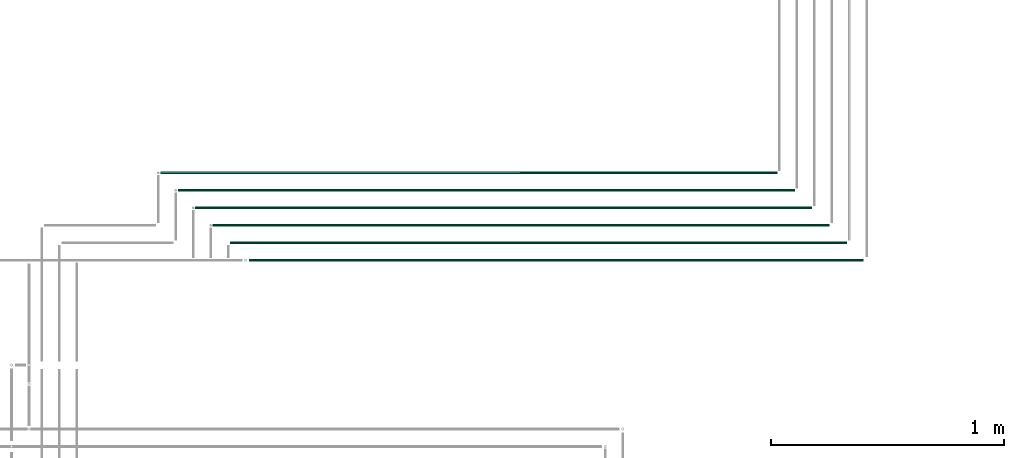
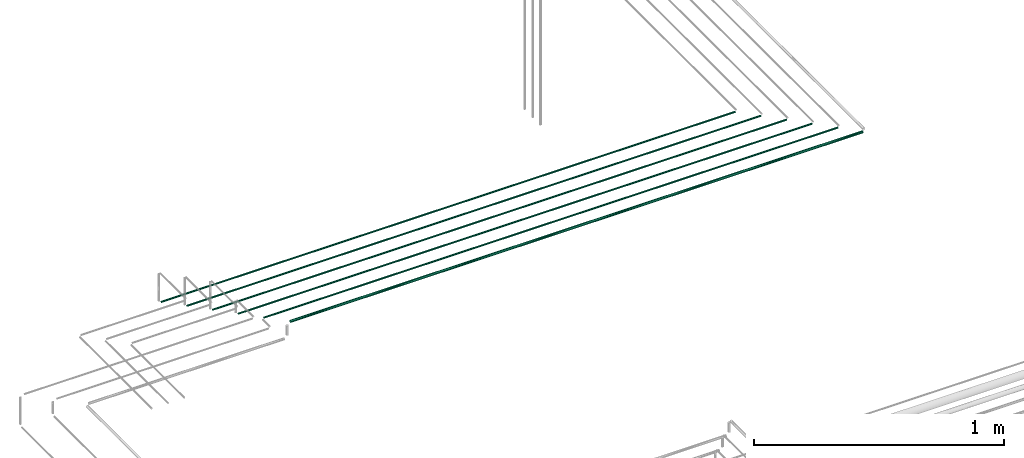
# One storey, part 30 of 331: 6 flow segments.
"""IFC2X3 building model written with IfcOpenShell, lengths in millimetres."""

from ifc_helpers import new_model, entity, si_unit, converted_unit, derived_unit, direction, frame, frame_2d, origin, place, context, subcontext, project, spatial, circle, extrude, type_object, element, save


model = new_model("IFC2X3")

# Units and contexts
model_context = context("Model", 3, precision=0.01, world=origin(), true_north=direction((6.12303176911189e-17, 1.0)))
body_context = subcontext(model_context, "Body", "Model", "MODEL_VIEW")
ifc_project = project(units=[si_unit("LENGTHUNIT", "METRE", prefix="MILLI"), si_unit("AREAUNIT", "SQUARE_METRE"), si_unit("VOLUMEUNIT", "CUBIC_METRE"), converted_unit("PLANEANGLEUNIT", "DEGREE", entity("IfcRatioMeasure", 0.0174532925199433), si_unit("PLANEANGLEUNIT", "RADIAN"), dimensions=[0, 0, 0, 0, 0, 0, 0]), si_unit("MASSUNIT", "GRAM", prefix="KILO"), derived_unit("MASSDENSITYUNIT", [(si_unit("MASSUNIT", "GRAM", prefix="KILO"), 1), (si_unit("LENGTHUNIT", "METRE"), -3)]), derived_unit("MOMENTOFINERTIAUNIT", [(si_unit("LENGTHUNIT", "METRE"), 4)]), si_unit("TIMEUNIT", "SECOND"), si_unit("FREQUENCYUNIT", "HERTZ"), si_unit("THERMODYNAMICTEMPERATUREUNIT", "DEGREE_CELSIUS"), derived_unit("THERMALTRANSMITTANCEUNIT", [(si_unit("MASSUNIT", "GRAM", prefix="KILO"), 1), (si_unit("THERMODYNAMICTEMPERATUREUNIT", "KELVIN"), -1), (si_unit("TIMEUNIT", "SECOND"), -3)]), derived_unit("VOLUMETRICFLOWRATEUNIT", [(si_unit("LENGTHUNIT", "METRE"), 3), (si_unit("TIMEUNIT", "SECOND"), -1)]), derived_unit("MASSFLOWRATEUNIT", [(si_unit("MASSUNIT", "GRAM", prefix="KILO"), 1), (si_unit("TIMEUNIT", "SECOND"), -1)]), derived_unit("ROTATIONALFREQUENCYUNIT", [(si_unit("TIMEUNIT", "SECOND"), -1)]), si_unit("ELECTRICCURRENTUNIT", "AMPERE"), si_unit("ELECTRICVOLTAGEUNIT", "VOLT"), si_unit("POWERUNIT", "WATT"), si_unit("FORCEUNIT", "NEWTON", prefix="KILO"), si_unit("ILLUMINANCEUNIT", "LUX"), si_unit("LUMINOUSFLUXUNIT", "LUMEN"), si_unit("LUMINOUSINTENSITYUNIT", "CANDELA"), derived_unit("USERDEFINED", [(si_unit("MASSUNIT", "GRAM", prefix="KILO"), -1), (si_unit("LENGTHUNIT", "METRE"), -2), (si_unit("TIMEUNIT", "SECOND"), 3), (si_unit("LUMINOUSFLUXUNIT", "LUMEN"), 1)]), derived_unit("LINEARVELOCITYUNIT", [(si_unit("LENGTHUNIT", "METRE"), 1), (si_unit("TIMEUNIT", "SECOND"), -1)]), si_unit("PRESSUREUNIT", "PASCAL"), derived_unit("USERDEFINED", [(si_unit("LENGTHUNIT", "METRE"), -2), (si_unit("MASSUNIT", "GRAM", prefix="KILO"), 1), (si_unit("TIMEUNIT", "SECOND"), -2)]), derived_unit("LINEARFORCEUNIT", [(si_unit("MASSUNIT", "GRAM", prefix="KILO"), 1), (si_unit("LENGTHUNIT", "METRE"), 1), (si_unit("TIMEUNIT", "SECOND"), -2), (si_unit("LENGTHUNIT", "METRE"), -1)]), derived_unit("PLANARFORCEUNIT", [(si_unit("MASSUNIT", "GRAM", prefix="KILO"), 1), (si_unit("LENGTHUNIT", "METRE"), 1), (si_unit("TIMEUNIT", "SECOND"), -2), (si_unit("LENGTHUNIT", "METRE"), -2)])], contexts=[model_context])

# Site, building, storey
site_placement = place(None, frame((0.0, -0.00077364408347762, 0.0)))
site = spatial("IfcSite", under=ifc_project, at=site_placement, CompositionType="ELEMENT")
building_placement = place(site_placement, origin())
building = spatial("IfcBuilding", under=site, at=building_placement, CompositionType="ELEMENT")
storey_placement = place(building_placement, origin())
storey = spatial("IfcBuildingStorey", under=building, at=storey_placement, CompositionType="ELEMENT", Elevation=0.0)

# Flow segments
pipe_segment_type = type_object("IfcPipeSegmentType", PredefinedType="NOTDEFINED")
flow_segment_1_placement = place(storey_placement, frame((38866.2598936965, 16767.3893979668, 7342.40472776409)))
element("IfcFlowSegment", 1, at=flow_segment_1_placement, inside=storey, type_object=pipe_segment_type, context=body_context, shape_type="SweptSolid", body=[
    extrude(circle(Radius=6.0, at=frame_2d((-2.16573425859679e-12, 6.49720277579036e-12), x_axis=(1.0, 0.0))), frame((0.0, 7.59527223592103, 7.59527223592212), z_axis=(1.0, 0.0, 0.0), x_axis=(0.0, 1.0, 0.0)), (0.0, 0.0, 1.0), 2639.74080210432),
])
flow_segment_2_placement = place(storey_placement, frame((38787.1427455742, 16844.3893979669, 7344.40472776408)))
element("IfcFlowSegment", 2, at=flow_segment_2_placement, inside=storey, type_object=pipe_segment_type, context=body_context, shape_type="SweptSolid", body=[
    extrude(circle(Radius=4.0, at=frame_2d((-4.33146851719357e-12, 5.41433564649196e-12), x_axis=(1.0, 0.0))), frame((0.0, 5.59527223591932, 5.59527223592365), z_axis=(1.0, 0.0, 0.0), x_axis=(0.0, 1.0, 0.0)), (0.0, 0.0, 1.0), 2647.85795022666),
])
flow_segment_3_placement = place(storey_placement, frame((38712.1427455742, 16919.3893979669, 7344.40472776408)))
element("IfcFlowSegment", 3, at=flow_segment_3_placement, inside=storey, type_object=pipe_segment_type, context=body_context, shape_type="SweptSolid", body=[
    extrude(circle(Radius=4.0, at=frame_2d((-1.43487688020857e-40, 5.41433564649196e-12), x_axis=(1.0, 0.0))), frame((0.0, 5.59527223591499, 5.59527223592365), z_axis=(1.0, 0.0, 0.0), x_axis=(0.0, 1.0, 0.0)), (0.0, 0.0, 1.0), 2647.85795022666),
])
flow_segment_4_placement = place(storey_placement, frame((38637.1427455742, 16994.3893979669, 7344.40472776408)))
element("IfcFlowSegment", 4, at=flow_segment_4_placement, inside=storey, type_object=pipe_segment_type, context=body_context, shape_type="SweptSolid", body=[
    extrude(circle(Radius=4.0, at=frame_2d((-1.43487688020857e-40, 5.41433564649196e-12), x_axis=(1.0, 0.0))), frame((0.0, 5.59527223591499, 5.59527223592365), z_axis=(1.0, 0.0, 0.0), x_axis=(0.0, 1.0, 0.0)), (0.0, 0.0, 1.0), 2647.85795022661),
])
flow_segment_5_placement = place(storey_placement, frame((38562.1427455742, 17069.3893979669, 7344.40472776408)))
element("IfcFlowSegment", 5, at=flow_segment_5_placement, inside=storey, type_object=pipe_segment_type, context=body_context, shape_type="SweptSolid", body=[
    extrude(circle(Radius=4.0, at=frame_2d((-1.43487688020857e-40, 5.41433564649196e-12), x_axis=(1.0, 0.0))), frame((0.0, 5.59527223591499, 5.59527223592365), z_axis=(1.0, 0.0, 0.0), x_axis=(0.0, 1.0, 0.0)), (0.0, 0.0, 1.0), 2647.85795022662),
])
flow_segment_6_placement = place(storey_placement, frame((38487.1427455742, 17144.3893979669, 7344.40472776408)))
element("IfcFlowSegment", 6, at=flow_segment_6_placement, inside=storey, type_object=pipe_segment_type, context=body_context, shape_type="SweptSolid", body=[
    extrude(circle(Radius=4.0, at=frame_2d((-1.43487688020857e-40, 5.41433564649196e-12), x_axis=(1.0, 0.0))), frame((0.0, 5.59527223591499, 5.59527223592365), z_axis=(1.0, 0.0, 0.0), x_axis=(0.0, 1.0, 0.0)), (0.0, 0.0, 1.0), 2647.85795022661),
])

save(model, "model.ifc")
